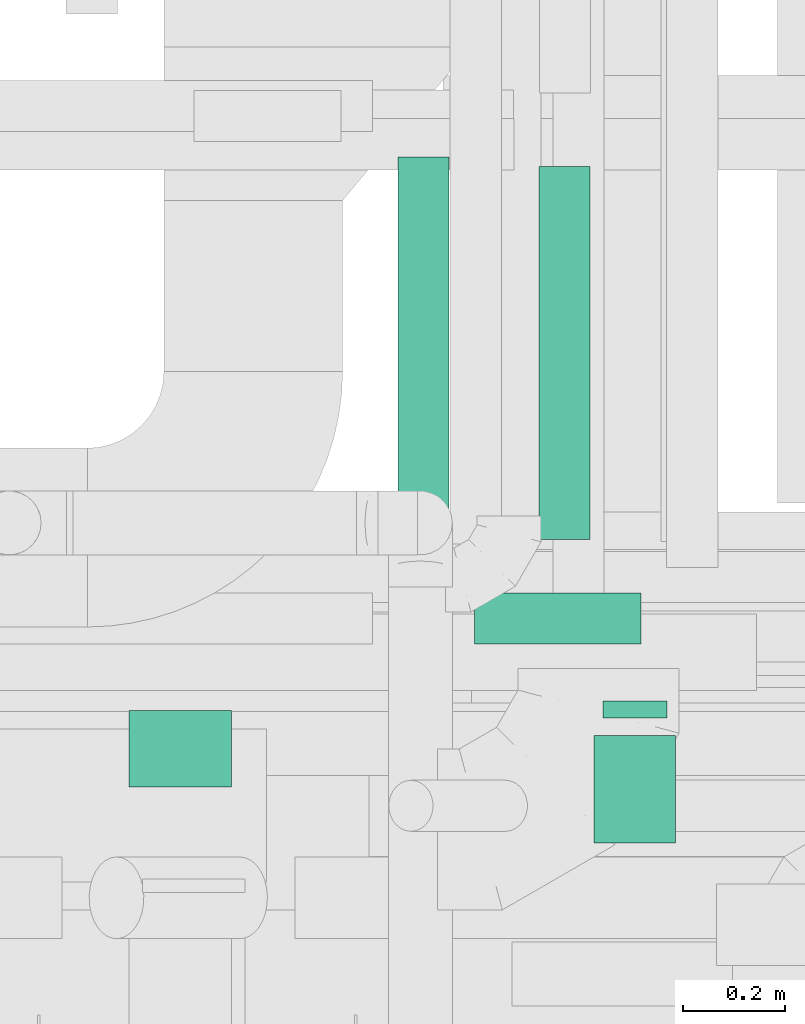
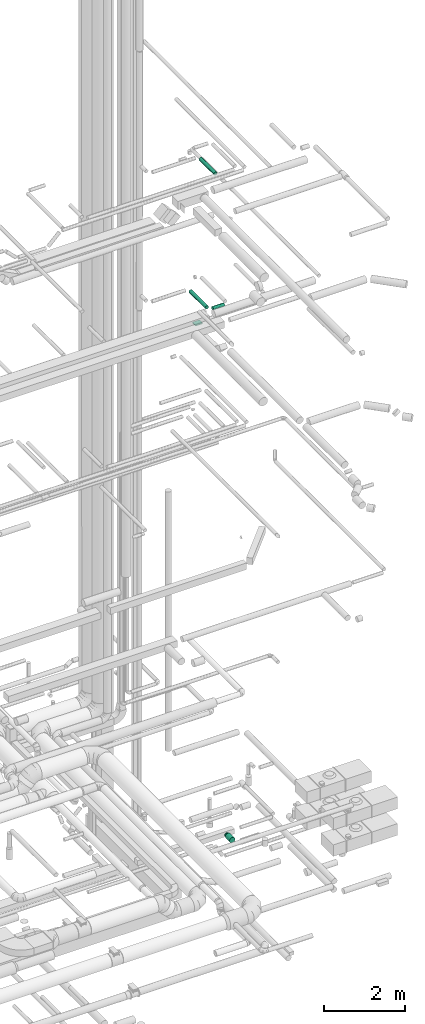
# One storey, part 263 of 337: 6 flow segments.
"""IFC2X3 building model written with IfcOpenShell, lengths in millimetres."""

from ifc_helpers import new_model, entity, si_unit, converted_unit, derived_unit, direction, frame, origin, origin_2d_with_axis, place, context, subcontext, project, spatial, rectangle, circle, extrude, type_object, element, save


model = new_model("IFC2X3")

# Units and contexts
model_context = context("Model", 3, precision=0.01, world=origin(), true_north=direction((6.12303176911189e-17, 1.0)))
body_context = subcontext(model_context, "Body", "Model", "MODEL_VIEW")
ifc_project = project(units=[si_unit("LENGTHUNIT", "METRE", prefix="MILLI"), si_unit("AREAUNIT", "SQUARE_METRE"), si_unit("VOLUMEUNIT", "CUBIC_METRE"), converted_unit("PLANEANGLEUNIT", "DEGREE", entity("IfcRatioMeasure", 0.0174532925199433), si_unit("PLANEANGLEUNIT", "RADIAN"), dimensions=[0, 0, 0, 0, 0, 0, 0]), si_unit("MASSUNIT", "GRAM", prefix="KILO"), derived_unit("MASSDENSITYUNIT", [(si_unit("MASSUNIT", "GRAM", prefix="KILO"), 1), (si_unit("LENGTHUNIT", "METRE"), -3)]), derived_unit("MOMENTOFINERTIAUNIT", [(si_unit("LENGTHUNIT", "METRE"), 4)]), si_unit("TIMEUNIT", "SECOND"), si_unit("FREQUENCYUNIT", "HERTZ"), si_unit("THERMODYNAMICTEMPERATUREUNIT", "DEGREE_CELSIUS"), derived_unit("THERMALTRANSMITTANCEUNIT", [(si_unit("MASSUNIT", "GRAM", prefix="KILO"), 1), (si_unit("THERMODYNAMICTEMPERATUREUNIT", "KELVIN"), -1), (si_unit("TIMEUNIT", "SECOND"), -3)]), derived_unit("VOLUMETRICFLOWRATEUNIT", [(si_unit("LENGTHUNIT", "METRE"), 3), (si_unit("TIMEUNIT", "SECOND"), -1)]), derived_unit("MASSFLOWRATEUNIT", [(si_unit("MASSUNIT", "GRAM", prefix="KILO"), 1), (si_unit("TIMEUNIT", "SECOND"), -1)]), derived_unit("ROTATIONALFREQUENCYUNIT", [(si_unit("TIMEUNIT", "SECOND"), -1)]), si_unit("ELECTRICCURRENTUNIT", "AMPERE"), si_unit("ELECTRICVOLTAGEUNIT", "VOLT"), si_unit("POWERUNIT", "WATT"), si_unit("FORCEUNIT", "NEWTON", prefix="KILO"), si_unit("ILLUMINANCEUNIT", "LUX"), si_unit("LUMINOUSFLUXUNIT", "LUMEN"), si_unit("LUMINOUSINTENSITYUNIT", "CANDELA"), derived_unit("USERDEFINED", [(si_unit("MASSUNIT", "GRAM", prefix="KILO"), -1), (si_unit("LENGTHUNIT", "METRE"), -2), (si_unit("TIMEUNIT", "SECOND"), 3), (si_unit("LUMINOUSFLUXUNIT", "LUMEN"), 1)]), derived_unit("LINEARVELOCITYUNIT", [(si_unit("LENGTHUNIT", "METRE"), 1), (si_unit("TIMEUNIT", "SECOND"), -1)]), si_unit("PRESSUREUNIT", "PASCAL"), derived_unit("USERDEFINED", [(si_unit("LENGTHUNIT", "METRE"), -2), (si_unit("MASSUNIT", "GRAM", prefix="KILO"), 1), (si_unit("TIMEUNIT", "SECOND"), -2)]), derived_unit("LINEARFORCEUNIT", [(si_unit("MASSUNIT", "GRAM", prefix="KILO"), 1), (si_unit("LENGTHUNIT", "METRE"), 1), (si_unit("TIMEUNIT", "SECOND"), -2), (si_unit("LENGTHUNIT", "METRE"), -1)]), derived_unit("PLANARFORCEUNIT", [(si_unit("MASSUNIT", "GRAM", prefix="KILO"), 1), (si_unit("LENGTHUNIT", "METRE"), 1), (si_unit("TIMEUNIT", "SECOND"), -2), (si_unit("LENGTHUNIT", "METRE"), -2)])], contexts=[model_context])

# Site, building, storey
site_placement = place(None, origin())
site = spatial("IfcSite", under=ifc_project, at=site_placement, CompositionType="ELEMENT")
building_placement = place(site_placement, origin())
building = spatial("IfcBuilding", under=site, at=building_placement, CompositionType="ELEMENT")
storey_placement = place(building_placement, origin())
storey = spatial("IfcBuildingStorey", under=building, at=storey_placement, CompositionType="ELEMENT", Elevation=0.0)

# Flow segments
duct_segment_type_1 = type_object("IfcDuctSegmentType", PredefinedType="NOTDEFINED")
flow_segment_1_placement = place(storey_placement, frame((69187.53, 9909.99, 15195.0)))
element("IfcFlowSegment", 1, at=flow_segment_1_placement, inside=storey, type_object=duct_segment_type_1, context=body_context, shape_type="SweptSolid", body=[
    extrude(rectangle(XDim=150.000000000001, YDim=199.999999999998, at=origin_2d_with_axis()), frame((100.0, 75.0, 0.0), z_axis=(0.0, 0.0, 1.0), x_axis=(0.0, -1.0, 0.0)), (0.0, 0.0, 1.0), 34.9999654568793),
])
duct_segment_type_2 = type_object("IfcDuctSegmentType", PredefinedType="NOTDEFINED")
flow_segment_2_placement = place(storey_placement, frame((70113.14, 10045.77, -614.1)))
element("IfcFlowSegment", 2, at=flow_segment_2_placement, inside=storey, type_object=duct_segment_type_2, context=body_context, shape_type="SweptSolid", body=[
    extrude(circle(Radius=62.5, at=origin_2d_with_axis()), frame((64.1, 0.0, 64.1), z_axis=(0.0, 1.0, 0.0), x_axis=(1.0, 0.0, 0.0)), (0.0, 0.0, 1.0), 33.2897157502389),
])
flow_segment_3_placement = place(storey_placement, frame((70095.64, 9801.0, -631.6)))
element("IfcFlowSegment", 3, at=flow_segment_3_placement, inside=storey, type_object=duct_segment_type_2, context=body_context, shape_type="SweptSolid", body=[
    extrude(circle(Radius=80.0, at=origin_2d_with_axis()), frame((81.6, 0.0, 81.6), z_axis=(0.0, 1.0, 0.0), x_axis=(-1.0, 0.0, 0.0)), (0.0, 0.0, 1.0), 209.769824249999),
])
flow_segment_4_placement = place(storey_placement, frame((69711.89, 10340.36, 15248.4)))
element("IfcFlowSegment", 4, at=flow_segment_4_placement, inside=storey, type_object=duct_segment_type_2, context=body_context, shape_type="SweptSolid", body=[
    extrude(circle(Radius=50.0, at=origin_2d_with_axis()), frame((51.6, 0.0, 51.6), z_axis=(0.0, 1.0, 0.0), x_axis=(-1.0, 0.0, 0.0)), (0.0, 0.0, 1.0), 802.95315),
])
flow_segment_5_placement = place(storey_placement, frame((69863.48, 10188.76, 15248.4)))
element("IfcFlowSegment", 5, at=flow_segment_5_placement, inside=storey, type_object=duct_segment_type_2, context=body_context, shape_type="SweptSolid", body=[
    extrude(circle(Radius=50.0, at=origin_2d_with_axis()), frame((0.0, 51.6, 51.6), z_axis=(1.0, 0.0, 0.0), x_axis=(0.0, -1.0, 0.0)), (0.0, 0.0, 1.0), 326.227890000008),
])
flow_segment_6_placement = place(storey_placement, frame((69988.23, 10395.19, 19148.4)))
element("IfcFlowSegment", 6, at=flow_segment_6_placement, inside=storey, type_object=duct_segment_type_2, context=body_context, shape_type="SweptSolid", body=[
    extrude(circle(Radius=50.0, at=origin_2d_with_axis()), frame((51.6, 0.0, 51.6), z_axis=(0.0, 1.0, 0.0), x_axis=(-1.0, 0.0, 0.0)), (0.0, 0.0, 1.0), 730.000000000029),
])

save(model, "model.ifc")
